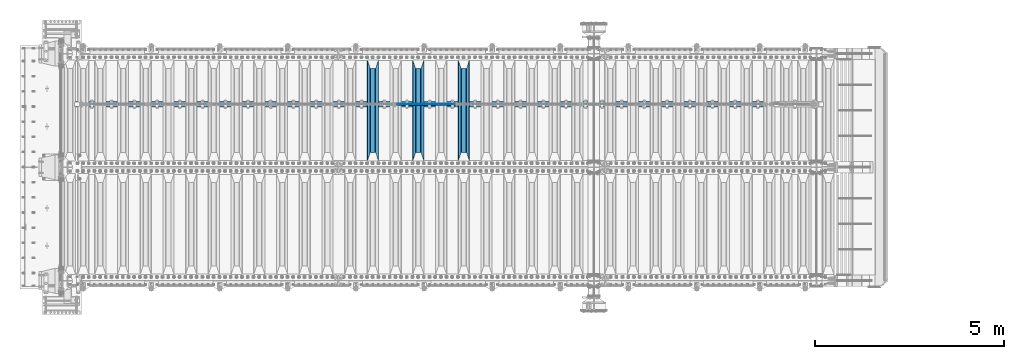
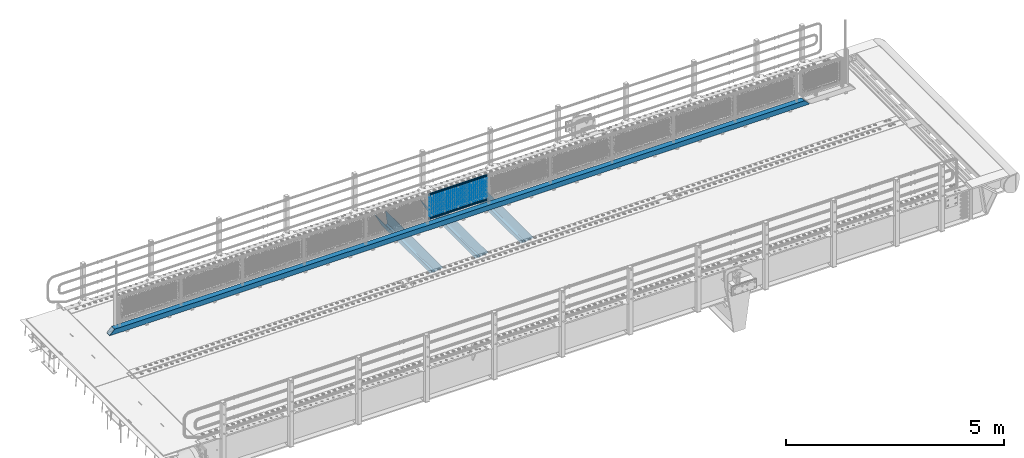
# One storey, part 123 of 242: 23 beams.
"""IFC2X3 building model written with IfcOpenShell, lengths in millimetres."""

import ifcopenshell
import ifcopenshell.guid

model = None  # the IFC model being written
_history = None  # IfcOwnerHistory: only IFC2X3 demands one
_inside = {}  # id of a spatial element -> (the spatial element, [elements in it])
_under = {}  # id of a project, library or spatial element -> (it, [spatial elements below it])
_declared = {}  # id of a project -> (the project, [libraries it declares])
_typed = {}  # id of a type object -> (the type object, [elements of that type])
_made_of = {}  # id of a material, layer set ... -> (it, [elements and type objects made of it])


def new_model(schema):
    """Start an empty IFC model of exactly this schema.

    Asked for "IFC4X3", IfcOpenShell would pick the latest addendum, in which some entities
    have other attributes; the version numbers below select the first issue.
    IFC2X3 requires an IfcOwnerHistory on every rooted entity: one is made here for all.
    """
    global model, _history
    if schema == "IFC4X3":
        model = ifcopenshell.file(schema_version=(4, 3, 0, 0))
    else:
        model = ifcopenshell.file(schema=schema)
    _inside.clear()
    _under.clear()
    _declared.clear()
    _typed.clear()
    _made_of.clear()
    _history = None
    if model.schema == "IFC2X3":
        org = make("IfcOrganization", Name="unknown")
        user = make(
            "IfcPersonAndOrganization",
            ThePerson=make("IfcPerson", FamilyName="unknown"),
            TheOrganization=org,
        )
        app = make(
            "IfcApplication",
            ApplicationDeveloper=org,
            Version="unknown",
            ApplicationFullName="unknown",
            ApplicationIdentifier="unknown",
        )
        _history = make(
            "IfcOwnerHistory",
            OwningUser=user,
            OwningApplication=app,
            ChangeAction="ADDED",
            CreationDate=0,
        )
    return model


def make(cls, **values):
    """One entity of the class cls with the attributes given. An attribute that is None is left unset."""
    return model.create_entity(
        cls, **{name: value for name, value in values.items() if value is not None}
    )


def rooted(cls, **values):
    """An entity with a GlobalId (a new one), such as an element, a storey or a relation."""
    return make(cls, GlobalId=ifcopenshell.guid.new(), OwnerHistory=_history, **values)


def si_unit(unit_type, name, prefix=None):
    """IfcSIUnit, for example si_unit("LENGTHUNIT", "METRE", prefix="MILLI")."""
    return make("IfcSIUnit", UnitType=unit_type, Prefix=prefix, Name=name)


def assignment(units):
    """IfcUnitAssignment: the units of a project."""
    return None if units is None else make("IfcUnitAssignment", Units=units)


def point(xyz):
    """IfcCartesianPoint."""
    return None if xyz is None else make("IfcCartesianPoint", Coordinates=xyz)


def direction(xyz):
    """IfcDirection."""
    return None if xyz is None else make("IfcDirection", DirectionRatios=xyz)


def frame(location, z_axis=None, x_axis=None):
    """IfcAxis2Placement3D, a coordinate frame: its origin and axes. An axis left out is left unset."""
    return make(
        "IfcAxis2Placement3D",
        Location=point(location),
        Axis=direction(z_axis),
        RefDirection=direction(x_axis),
    )


def origin_with_axes():
    """The frame at (0, 0, 0) with the z axis (0, 0, 1) and the x axis (1, 0, 0) written out."""
    return frame((0.0, 0.0, 0.0), z_axis=(0.0, 0.0, 1.0), x_axis=(1.0, 0.0, 0.0))


def place(relative_to, where):
    """IfcLocalPlacement: puts the frame where relative to a parent placement (None: the world)."""
    return make(
        "IfcLocalPlacement", PlacementRelTo=relative_to, RelativePlacement=where
    )


def context(
    kind, dimensions, precision=None, world=None, true_north=None, identifier=None
):
    """IfcGeometricRepresentationContext, for example the 3D "Model" context."""
    return make(
        "IfcGeometricRepresentationContext",
        ContextIdentifier=identifier,
        ContextType=kind,
        CoordinateSpaceDimension=dimensions,
        Precision=precision,
        WorldCoordinateSystem=world,
        TrueNorth=true_north,
    )


def subcontext(parent, identifier, kind, view, scale=None):
    """IfcGeometricRepresentationSubContext, for example "Body" below "Model"."""
    return make(
        "IfcGeometricRepresentationSubContext",
        ContextIdentifier=identifier,
        ContextType=kind,
        ParentContext=parent,
        TargetScale=scale,
        TargetView=view,
    )


def project(units=None, contexts=None):
    """IfcProject with its units and contexts."""
    return rooted(
        "IfcProject",
        Name="project",
        RepresentationContexts=contexts,
        UnitsInContext=assignment(units),
    )


def spatial(cls, under=None, at=None, **own):
    """A site, building, storey or space (cls), placed at a placement, below another one or the project."""
    s = rooted(cls, ObjectPlacement=at, **own)
    if under is not None:
        _under.setdefault(under.id(), (under, []))[1].append(s)
    return s


def faces_of(points, faces, orient=None, outer=None):
    """IfcFace entities. A face is a list of loops; a loop is a list of indices into points, from 0.

    orient and outer hold one flag for each loop. By default every Orientation is true, the
    first loop of a face is its IfcFaceOuterBound and the others are IfcFaceBound.
    """
    made = []
    for i, loops in enumerate(faces):
        bounds = []
        for j, loop in enumerate(loops):
            is_outer = j == 0 if outer is None else outer[i][j]
            bounds.append(
                make(
                    "IfcFaceOuterBound" if is_outer else "IfcFaceBound",
                    Bound=make("IfcPolyLoop", Polygon=[points[k] for k in loop]),
                    Orientation=True if orient is None else orient[i][j],
                )
            )
        made.append(make("IfcFace", Bounds=bounds))
    return made


def faceted_brep(points, faces, orient=None, outer=None, voids=None):
    """IfcFacetedBrep: a solid bounded by flat faces; with voids (closed shells), ...WithVoids."""
    shared = [point(p) for p in points]
    hull = make("IfcClosedShell", CfsFaces=faces_of(shared, faces, orient, outer))
    if voids is None:
        return make("IfcFacetedBrep", Outer=hull)
    return make(
        "IfcFacetedBrepWithVoids",
        Outer=hull,
        Voids=[
            make(cls, CfsFaces=faces_of(shared, fs, o, b)) for cls, fs, o, b in voids
        ],
    )


def shape(context_of_items, identifier, shape_type, items):
    """IfcShapeRepresentation: the items that make up one representation, for example the "Body"."""
    return make(
        "IfcShapeRepresentation",
        ContextOfItems=context_of_items,
        RepresentationIdentifier=identifier,
        RepresentationType=shape_type,
        Items=items,
    )


def material(Name=None, Category=None):
    """IfcMaterial."""
    return make("IfcMaterial", Name=Name, Category=Category)


def made_of(thing, what):
    """Note that an element or type object is made of a material, layer set ...; save() writes the relation."""
    if what is not None:
        _made_of.setdefault(what.id(), (what, []))[1].append(thing)
    return thing


def type_object(cls, material=None, **own):
    """A type object (cls), such as IfcWallType, which elements share."""
    return made_of(rooted(cls, **own), material)


def element(
    cls,
    number,
    at=None,
    inside=None,
    cuts=None,
    type_object=None,
    material=None,
    context=None,
    identifier="Body",
    shape_type=None,
    held_by="IfcProductDefinitionShape",
    body=None,
    shapes=None,
    **own,
):
    """One element of the class cls, such as IfcWall. Its Tag is "e" and its number.

    at: its placement. inside: the storey or other place that contains it. cuts: it is an
    opening in that element (IfcRelVoidsElement). A single representation is given by context,
    identifier, shape_type and body (its items); several are given by shapes. held_by: the class
    of the entity that holds the representations. save() writes the other relations.
    """
    e = rooted(cls, Tag="e%d" % number, ObjectPlacement=at, **own)
    if body is not None:
        shapes = [shape(context, identifier, shape_type, body)]
    if shapes is not None:
        e.Representation = make(held_by, Representations=shapes)
    if inside is not None:
        _inside.setdefault(inside.id(), (inside, []))[1].append(e)
    if cuts is not None:
        rooted(
            "IfcRelVoidsElement", RelatingBuildingElement=cuts, RelatedOpeningElement=e
        )
    if type_object is not None:
        _typed.setdefault(type_object.id(), (type_object, []))[1].append(e)
    return made_of(e, material)


def aggregate(whole, parts):
    """IfcRelAggregates: a whole, such as a stair, and the parts it consists of."""
    return rooted("IfcRelAggregates", RelatingObject=whole, RelatedObjects=parts)


def save(model, path):
    """Write the relations noted so far, then the file.

    IfcRelAggregates (storeys below a building ...), IfcRelContainedInSpatialStructure (elements
    in a storey), IfcRelDefinesByType, IfcRelAssociatesMaterial and IfcRelDeclares: one each for
    every whole, place, type object, material and project.
    """
    for whole, parts in _under.values():
        aggregate(whole, parts)
    for where, things in _inside.values():
        rooted(
            "IfcRelContainedInSpatialStructure",
            RelatedElements=things,
            RelatingStructure=where,
        )
    for kind, things in _typed.values():
        rooted("IfcRelDefinesByType", RelatedObjects=things, RelatingType=kind)
    for what, things in _made_of.values():
        rooted("IfcRelAssociatesMaterial", RelatedObjects=things, RelatingMaterial=what)
    for by, libraries in _declared.values():
        rooted("IfcRelDeclares", RelatingContext=by, RelatedDefinitions=libraries)
    model.write(path)


model = new_model("IFC2X3")

# Units and contexts
model_context = context("Model", 3, precision=1e-05, world=origin_with_axes())
body_context = subcontext(model_context, "Body", "Model", "MODEL_VIEW")
ifc_project = project(units=[si_unit("LENGTHUNIT", "METRE", prefix="MILLI"), si_unit("AREAUNIT", "SQUARE_METRE"), si_unit("VOLUMEUNIT", "CUBIC_METRE"), si_unit("MASSUNIT", "GRAM", prefix="KILO"), si_unit("TIMEUNIT", "SECOND"), si_unit("PLANEANGLEUNIT", "RADIAN"), si_unit("SOLIDANGLEUNIT", "STERADIAN"), si_unit("THERMODYNAMICTEMPERATUREUNIT", "DEGREE_CELSIUS"), si_unit("LUMINOUSINTENSITYUNIT", "LUMEN")], contexts=[model_context])

# Site, building, storey
site_placement = place(None, origin_with_axes())
site = spatial("IfcSite", under=ifc_project, at=site_placement, CompositionType="ELEMENT")
building_placement = place(site_placement, origin_with_axes())
building = spatial("IfcBuilding", under=site, at=building_placement, Name="Standard", CompositionType="ELEMENT")
storey_placement = place(building_placement, origin_with_axes())
storey = spatial("IfcBuildingStorey", under=building, at=storey_placement, Name="Undefined", CompositionType="ELEMENT", Elevation=0.0)

# Beams
ifc_material_1 = material(Name="Misc_Undefined")
beam_type_1 = type_object("IfcBeamType", Name="D3", PredefinedType="NOTDEFINED")
for number, where, z_axis, x_axis in (
    (1, (-33609.0, -19329.5, 851.596999999999), (0.0, 0.0, 1.0), (1.0, 0.0, 0.0)),
    (2, (-33609.0, -19329.5, 669.452), (0.0, 0.0, 1.0), (1.0, 0.0, 0.0)),
    (3, (-33609.0, -19329.5, 523.736), (0.0, 0.0, 1.0), (1.0, 0.0, 0.0)),
    (4, (-33609.0, -19329.5, 487.307), (0.0, 0.0, 1.0), (1.0, 0.0, 0.0)),
    (5, (-33609.0, -19329.5, 705.881), (0.0, 0.0, 1.0), (1.0, 0.0, 0.0)),
    (6, (-33609.0, -19329.5, 596.594), (0.0, 0.0, 1.0), (1.0, 0.0, 0.0)),
    (7, (-33609.0, -19329.5, 450.878), (0.0, 0.0, 1.0), (1.0, 0.0, 0.0)),
    (8, (-33609.0, -19329.5, 815.167999999999), (0.0, 0.0, 1.0), (1.0, 0.0, 0.0)),
    (9, (-33609.0, -19329.5, 888.025999999999), (0.0, 0.0, 1.0), (1.0, 0.0, 0.0)),
    (10, (-33609.0, -19329.5, 778.738999999999), (0.0, 0.0, 1.0), (1.0, 0.0, 0.0)),
    (11, (-33609.0, -19329.5, 742.309999999999), (0.0, 0.0, 1.0), (1.0, 0.0, 0.0)),
    (12, (-33609.0, -19329.5, 633.023), (0.0, 0.0, 1.0), (1.0, 0.0, 0.0)),
    (13, (-33609.0, -19329.5, 560.165), (0.0, 0.0, 1.0), (1.0, 0.0, 0.0)),
    (14, (-33609.0, -19329.5, 414.449), (0.0, 0.0, 1.0), (1.0, 0.0, 0.0)),
):
    element("IfcBeam", number, at=place(storey_placement, frame(where, z_axis=z_axis, x_axis=x_axis)), inside=storey, type_object=beam_type_1, material=ifc_material_1, ObjectType="D3", context=body_context, shape_type="Brep", body=[
        faceted_brep([(0.0, -1.50000000000364, 0.0), (-3.63797880709171e-12, -0.750000000003638, -1.29903810567669), (1523.0, -0.75, -1.29903810567669), (1523.0, -1.5, 0.0), (0.0, 0.749999999996362, -1.29903810567669), (1523.0, 0.75, -1.29903810567669), (-3.63797880709171e-12, 1.49999999999636, 0.0), (1523.0, 1.5, 0.0), (0.0, 0.749999999996362, 1.29903810567669), (1523.0, 0.75, 1.29903810567669), (-3.63797880709171e-12, -0.750000000003638, 1.29903810567669), (1523.0, -0.75, 1.29903810567669)], [[[0, 1, 2, 3]], [[1, 4, 5, 2]], [[4, 6, 7, 5]], [[6, 8, 9, 7]], [[8, 10, 11, 9]], [[10, 0, 3, 11]], [[5, 7, 9, 11, 3, 2]], [[10, 8, 6, 4, 1, 0]]]),
    ])
beam_1_placement = place(storey_placement, frame((-33584.0, -19329.5, 353.02), z_axis=(0.0, 0.0, 1.0), x_axis=(1.0, 0.0, 0.0)))
element("IfcBeam", 15, at=beam_1_placement, inside=storey, type_object=beam_type_1, material=ifc_material_1, ObjectType="D3", context=body_context, shape_type="Brep", body=[
    faceted_brep([(0.0, -1.50000000000364, 0.0), (-3.63797880709171e-12, -0.750000000003638, -1.29903810567669), (1473.0, -0.75, -1.29903810567669), (1473.0, -1.5, 0.0), (0.0, 0.749999999996362, -1.29903810567669), (1473.0, 0.75, -1.29903810567663), (-3.63797880709171e-12, 1.49999999999636, 0.0), (1473.0, 1.5, 0.0), (0.0, 0.749999999996362, 1.29903810567669), (1473.0, 0.75, 1.29903810567669), (-3.63797880709171e-12, -0.750000000003638, 1.29903810567669), (1473.0, -0.75, 1.29903810567669)], [[[0, 1, 2, 3]], [[1, 4, 5, 2]], [[4, 6, 7, 5]], [[6, 8, 9, 7]], [[8, 10, 11, 9]], [[10, 0, 3, 11]], [[5, 7, 9, 11, 3, 2]], [[10, 8, 6, 4, 1, 0]]]),
])
beam_2_placement = place(storey_placement, frame((-33609.0, -19329.5, 378.02), z_axis=(0.0, 0.0, 1.0), x_axis=(1.0, 0.0, 0.0)))
element("IfcBeam", 16, at=beam_2_placement, inside=storey, type_object=beam_type_1, material=ifc_material_1, ObjectType="D3", context=body_context, shape_type="Brep", body=[
    faceted_brep([(0.0, -1.50000000000364, 0.0), (-3.63797880709171e-12, -0.750000000003638, -1.29903810567669), (1523.0, -0.75, -1.29903810567669), (1523.0, -1.5, 0.0), (0.0, 0.749999999996362, -1.29903810567669), (1523.0, 0.75, -1.29903810567669), (-3.63797880709171e-12, 1.49999999999636, 0.0), (1523.0, 1.5, 0.0), (0.0, 0.749999999996362, 1.29903810567669), (1523.0, 0.75, 1.29903810567669), (-3.63797880709171e-12, -0.750000000003638, 1.29903810567669), (1523.0, -0.75, 1.29903810567669)], [[[0, 1, 2, 3]], [[1, 4, 5, 2]], [[4, 6, 7, 5]], [[6, 8, 9, 7]], [[8, 10, 11, 9]], [[10, 0, 3, 11]], [[5, 7, 9, 11, 3, 2]], [[10, 8, 6, 4, 1, 0]]]),
])
beam_3_placement = place(storey_placement, frame((-33584.0, -19329.5, 913.02), z_axis=(0.0, 0.0, 1.0), x_axis=(1.0, 0.0, 0.0)))
element("IfcBeam", 17, at=beam_3_placement, inside=storey, type_object=beam_type_1, material=ifc_material_1, ObjectType="D3", context=body_context, shape_type="Brep", body=[
    faceted_brep([(0.0, -1.50000000000364, 0.0), (-3.63797880709171e-12, -0.750000000003638, -1.29903810567669), (1473.0, -0.75, -1.29903810567669), (1473.0, -1.5, 0.0), (0.0, 0.749999999996362, -1.29903810567669), (1473.0, 0.75, -1.29903810567663), (-3.63797880709171e-12, 1.49999999999636, 0.0), (1473.0, 1.5, 0.0), (0.0, 0.749999999996362, 1.29903810567669), (1473.0, 0.75, 1.29903810567669), (-3.63797880709171e-12, -0.750000000003638, 1.29903810567669), (1473.0, -0.75, 1.29903810567669)], [[[0, 1, 2, 3]], [[1, 4, 5, 2]], [[4, 6, 7, 5]], [[6, 8, 9, 7]], [[8, 10, 11, 9]], [[10, 0, 3, 11]], [[5, 7, 9, 11, 3, 2]], [[10, 8, 6, 4, 1, 0]]]),
])
ifc_material_2 = material()
beam_type_2 = type_object("IfcBeamType", PredefinedType="NOTDEFINED")
beam_4_placement = place(storey_placement, frame((-33629.15, -19335.5, 969.849999999999), z_axis=(0.0, 0.0, 1.0), x_axis=(1.0, 0.0, 0.0)))
element("IfcBeam", 18, at=beam_4_placement, inside=storey, type_object=beam_type_2, material=ifc_material_2, context=body_context, shape_type="Brep", body=[
    faceted_brep([(0.0, -25.3499999999985, 0.0), (0.0, -23.4203461491597, 9.70102501045403), (1563.0, -23.4203461491597, 9.70102501045506), (1563.0, -25.3499999999985, 0.0), (0.0, -17.9251569030785, 17.9251569030785), (1563.0, -17.9251569030785, 17.925156903079), (0.0, -9.70102501045403, 23.4203461491597), (1563.0, -9.70102501045403, 23.4203461491611), (0.0, 0.0, 25.3499999999985), (1563.0, 0.0, 25.35), (0.0, 9.70102501045403, 23.4203461491597), (1563.0, 9.70102501045403, 23.4203461491611), (0.0, 17.9251569030785, 17.9251569030785), (1563.0, 17.9251569030785, 17.925156903079), (0.0, 23.4203461491597, 9.70102501045403), (1563.0, 23.4203461491597, 9.70102501045506), (0.0, 25.3499999999985, 0.0), (1563.0, 25.3499999999985, 0.0), (0.0, 23.4203461491597, -9.70102501045403), (1563.0, 23.4203461491597, -9.70102501045506), (0.0, 17.9251569030785, -17.9251569030785), (1563.0, 17.9251569030785, -17.925156903079), (0.0, 9.70102501045403, -23.4203461491597), (1563.0, 9.70102501045403, -23.4203461491611), (0.0, 0.0, -25.3499999999985), (1563.0, 0.0, -25.35), (0.0, -9.70102501045403, -23.4203461491597), (1563.0, -9.70102501045403, -23.4203461491611), (0.0, -17.9251569030785, -17.9251569030785), (1563.0, -17.9251569030785, -17.925156903079), (0.0, -23.4203461491597, -9.70102501045403), (1563.0, -23.4203461491597, -9.70102501045506), (0.0, -30.1500000000015, 0.0), (0.0, -27.8549679052157, -11.5379054858058), (1563.0, -27.8549679052157, -11.5379054858075), (1563.0, -30.1500000000015, 0.0), (0.0, -21.3192694527752, -21.3192694527752), (1563.0, -21.3192694527752, -21.3192694527744), (0.0, -11.5379054858058, -27.8549679052157), (1563.0, -11.5379054858058, -27.8549679052153), (0.0, 0.0, -30.1500000000015), (1563.0, 0.0, -30.15), (0.0, 11.5379054858058, -27.8549679052157), (1563.0, 11.5379054858058, -27.8549679052153), (0.0, 21.3192694527752, -21.3192694527752), (1563.0, 21.3192694527752, -21.3192694527744), (0.0, 27.8549679052157, -11.5379054858058), (1563.0, 27.8549679052157, -11.5379054858074), (0.0, 30.1500000000015, 0.0), (1563.0, 30.1500000000015, 0.0), (0.0, 27.8549679052157, 11.5379054858058), (1563.0, 27.8549679052157, 11.5379054858074), (0.0, 21.3192694527752, 21.3192694527752), (1563.0, 21.3192694527752, 21.3192694527744), (0.0, 11.5379054858058, 27.8549679052157), (1563.0, 11.5379054858058, 27.8549679052153), (0.0, 0.0, 30.1500000000015), (1563.0, 0.0, 30.15), (0.0, -11.5379054858058, 27.8549679052157), (1563.0, -11.5379054858058, 27.8549679052153), (0.0, -21.3192694527752, 21.3192694527752), (1563.0, -21.3192694527752, 21.3192694527744), (0.0, -27.8549679052157, 11.5379054858058), (1563.0, -27.8549679052157, 11.5379054858074)], [[[0, 1, 2, 3]], [[1, 4, 5, 2]], [[4, 6, 7, 5]], [[6, 8, 9, 7]], [[8, 10, 11, 9]], [[10, 12, 13, 11]], [[12, 14, 15, 13]], [[14, 16, 17, 15]], [[16, 18, 19, 17]], [[18, 20, 21, 19]], [[20, 22, 23, 21]], [[22, 24, 25, 23]], [[24, 26, 27, 25]], [[26, 28, 29, 27]], [[28, 30, 31, 29]], [[30, 0, 3, 31]], [[32, 33, 34, 35]], [[33, 36, 37, 34]], [[36, 38, 39, 37]], [[38, 40, 41, 39]], [[40, 42, 43, 41]], [[42, 44, 45, 43]], [[44, 46, 47, 45]], [[46, 48, 49, 47]], [[48, 50, 51, 49]], [[50, 52, 53, 51]], [[52, 54, 55, 53]], [[54, 56, 57, 55]], [[56, 58, 59, 57]], [[58, 60, 61, 59]], [[60, 62, 63, 61]], [[62, 32, 35, 63]], [[37, 39, 41, 43, 45, 47, 49, 51, 53, 55, 57, 59, 61, 63, 35, 34], [5, 7, 9, 11, 13, 15, 17, 19, 21, 23, 25, 27, 29, 31, 3, 2]], [[62, 60, 58, 56, 54, 52, 50, 48, 46, 44, 42, 40, 38, 36, 33, 32], [30, 28, 26, 24, 22, 20, 18, 16, 14, 12, 10, 8, 6, 4, 1, 0]]]),
])
beam_5_placement = place(storey_placement, frame((-33629.15, -19335.5, 298.170000000001), z_axis=(0.0, 0.0, 1.0), x_axis=(1.0, 0.0, 0.0)))
element("IfcBeam", 19, at=beam_5_placement, inside=storey, type_object=beam_type_2, material=ifc_material_2, context=body_context, shape_type="Brep", body=[
    faceted_brep([(0.0, -25.3499999999985, 0.0), (0.0, -23.4203461491597, 9.70102501045403), (1563.0, -23.4203461491597, 9.70102501045506), (1563.0, -25.3499999999985, 0.0), (0.0, -17.9251569030785, 17.9251569030785), (1563.0, -17.9251569030785, 17.925156903079), (0.0, -9.70102501045403, 23.4203461491597), (1563.0, -9.70102501045403, 23.4203461491611), (0.0, 0.0, 25.3499999999985), (1563.0, 0.0, 25.35), (0.0, 9.70102501045403, 23.4203461491597), (1563.0, 9.70102501045403, 23.4203461491611), (0.0, 17.9251569030785, 17.9251569030785), (1563.0, 17.9251569030785, 17.925156903079), (0.0, 23.4203461491597, 9.70102501045403), (1563.0, 23.4203461491597, 9.70102501045506), (0.0, 25.3499999999985, 0.0), (1563.0, 25.3499999999985, 0.0), (0.0, 23.4203461491597, -9.70102501045403), (1563.0, 23.4203461491597, -9.70102501045506), (0.0, 17.9251569030785, -17.9251569030785), (1563.0, 17.9251569030785, -17.925156903079), (0.0, 9.70102501045403, -23.4203461491597), (1563.0, 9.70102501045403, -23.4203461491611), (0.0, 0.0, -25.3499999999985), (1563.0, 0.0, -25.35), (0.0, -9.70102501045403, -23.4203461491597), (1563.0, -9.70102501045403, -23.4203461491611), (0.0, -17.9251569030785, -17.9251569030785), (1563.0, -17.9251569030785, -17.925156903079), (0.0, -23.4203461491597, -9.70102501045403), (1563.0, -23.4203461491597, -9.70102501045506), (0.0, -30.1500000000015, 0.0), (0.0, -27.8549679052157, -11.5379054858058), (1563.0, -27.8549679052157, -11.5379054858075), (1563.0, -30.1500000000015, 0.0), (0.0, -21.3192694527752, -21.3192694527752), (1563.0, -21.3192694527752, -21.3192694527744), (0.0, -11.5379054858058, -27.8549679052157), (1563.0, -11.5379054858058, -27.8549679052153), (0.0, 0.0, -30.1500000000015), (1563.0, 0.0, -30.15), (0.0, 11.5379054858058, -27.8549679052157), (1563.0, 11.5379054858058, -27.8549679052153), (0.0, 21.3192694527752, -21.3192694527752), (1563.0, 21.3192694527752, -21.3192694527744), (0.0, 27.8549679052157, -11.5379054858058), (1563.0, 27.8549679052157, -11.5379054858074), (0.0, 30.1500000000015, 0.0), (1563.0, 30.1500000000015, 0.0), (0.0, 27.8549679052157, 11.5379054858058), (1563.0, 27.8549679052157, 11.5379054858074), (0.0, 21.3192694527752, 21.3192694527752), (1563.0, 21.3192694527752, 21.3192694527744), (0.0, 11.5379054858058, 27.8549679052157), (1563.0, 11.5379054858058, 27.8549679052153), (0.0, 0.0, 30.1500000000015), (1563.0, 0.0, 30.15), (0.0, -11.5379054858058, 27.8549679052157), (1563.0, -11.5379054858058, 27.8549679052153), (0.0, -21.3192694527752, 21.3192694527752), (1563.0, -21.3192694527752, 21.3192694527744), (0.0, -27.8549679052157, 11.5379054858058), (1563.0, -27.8549679052157, 11.5379054858074)], [[[0, 1, 2, 3]], [[1, 4, 5, 2]], [[4, 6, 7, 5]], [[6, 8, 9, 7]], [[8, 10, 11, 9]], [[10, 12, 13, 11]], [[12, 14, 15, 13]], [[14, 16, 17, 15]], [[16, 18, 19, 17]], [[18, 20, 21, 19]], [[20, 22, 23, 21]], [[22, 24, 25, 23]], [[24, 26, 27, 25]], [[26, 28, 29, 27]], [[28, 30, 31, 29]], [[30, 0, 3, 31]], [[32, 33, 34, 35]], [[33, 36, 37, 34]], [[36, 38, 39, 37]], [[38, 40, 41, 39]], [[40, 42, 43, 41]], [[42, 44, 45, 43]], [[44, 46, 47, 45]], [[46, 48, 49, 47]], [[48, 50, 51, 49]], [[50, 52, 53, 51]], [[52, 54, 55, 53]], [[54, 56, 57, 55]], [[56, 58, 59, 57]], [[58, 60, 61, 59]], [[60, 62, 63, 61]], [[62, 32, 35, 63]], [[37, 39, 41, 43, 45, 47, 49, 51, 53, 55, 57, 59, 61, 63, 35, 34], [5, 7, 9, 11, 13, 15, 17, 19, 21, 23, 25, 27, 29, 31, 3, 2]], [[62, 60, 58, 56, 54, 52, 50, 48, 46, 44, 42, 40, 38, 36, 33, 32], [30, 28, 26, 24, 22, 20, 18, 16, 14, 12, 10, 8, 6, 4, 1, 0]]]),
])
beam_type_3 = type_object("IfcBeamType", PredefinedType="NOTDEFINED")
beam_6_placement = place(storey_placement, frame((-42125.0, -19335.5, 98.0199999999977), z_axis=(0.0, 0.0, 1.0), x_axis=(1.0, 0.0, 0.0)))
element("IfcBeam", 20, at=beam_6_placement, inside=storey, type_object=beam_type_3, material=ifc_material_2, context=body_context, shape_type="Brep", body=[
    faceted_brep([(0.0, -70.0, -70.0), (0.0, 70.0, -70.0), (18565.0, 70.0, -70.0), (18565.0, -70.0, -70.0), (18434.8884698478, -70.0, 70.0), (18434.8884698478, 70.0, 70.0), (130.111530936148, 70.0, 70.0), (130.111528976151, -70.0, 70.0), (18565.0, -70.0, -60.0079600980746), (0.0, -70.0, -60.0079591069155), (18444.8964362873, -60.0, 60.0), (18565.0, -60.0, -60.0), (0.0, -60.0, -60.0), (120.103562690863, -60.0, 60.0), (18444.8964362873, 60.0, 60.0), (120.10356437086, 60.0, 60.0), (18565.0, 60.0, -60.0), (0.0, 60.0, -60.0), (18565.0, 70.0, -60.0079600980746), (0.0, 70.0, -60.0079610653521)], [[[0, 1, 2, 3]], [[4, 5, 6, 7]], [[0, 3, 8, 4, 7, 9]], [[10, 11, 12, 13]], [[14, 10, 13, 15]], [[16, 14, 15, 17]], [[4, 8, 11, 10, 14, 16, 18, 5]], [[11, 8, 3, 2, 18, 16]], [[17, 12, 11, 16]], [[1, 0, 9, 12, 17, 19]], [[5, 18, 2, 1, 19, 6]], [[17, 15, 13, 12, 9, 7, 6, 19]]]),
])
ifc_material_3 = material(Name="STEEL/S355N")
beam_type_4 = type_object("IfcBeamType", PredefinedType="NOTDEFINED")
beam_7_placement = place(storey_placement, frame((-31850.0, -20825.0, -115.0), z_axis=(0.0, 0.0, 1.0), x_axis=(0.0, 1.0, 0.0)))
element("IfcBeam", 21, at=beam_7_placement, inside=storey, type_object=beam_type_4, material=ifc_material_3, context=body_context, shape_type="Brep", body=[
    faceted_brep([(0.0, 150.0, 115.0), (0.0, 143.689999999999, 115.0), (2650.00000000297, 143.689999999999, 115.0), (2650.00000000297, 150.0, 115.0), (2650.00000000297, 142.059565218402, 110.000000003099), (2650.00000000297, 148.369565218403, 110.000000003099), (2441.90079219209, -80.1103600731112, -98.0992078077845), (2437.7588105432, -77.5672621345584, -102.241189456673), (2434.06523489747, -74.4080125315522, -105.934765102404), (2430.91086095089, -70.710272125576, -109.089139048974), (2428.37322971128, -66.5649389910068, -111.626770288588), (2426.51472138055, -62.0739139532889, -113.485278619323), (2425.38102192092, -57.3475956567672, -114.618978078955), (2424.99999999987, -52.5021667386536, -115.0), (2424.99999999987, 52.5021667386536, -115.0), (2425.38102192092, 57.3475956567672, -114.618978078955), (2426.51472138055, 62.0739139532889, -113.485278619323), (2428.37322971128, 66.5649389910068, -111.626770288588), (2430.91086095089, 70.710272125576, -109.089139048974), (2434.06523489747, 74.4080125315522, -105.934765102404), (2437.7588105432, 77.5672621345584, -102.241189456673), (2441.90079219209, 80.1103600731112, -98.0992078077846), (2446.38936140511, 81.9747917625791, -93.6106385947584), (2448.2494850041, 76.2713538057251, -91.7505149957729), (2444.62967112262, 74.76777986261, -95.3703288772456), (2441.28936334126, 72.7168944282894, -98.710636658607), (2438.31067330438, 70.1691124903846, -101.689326695487), (2435.76682334747, 67.1870637758839, -104.233176652398), (2433.72034654133, 63.8440531834895, -106.279653458539), (2432.22154950042, 60.222258798236, -107.778450499454), (2431.30727574265, 56.4107117849089, -108.692724257221), (2430.99999999987, 52.5031078186876, -109.0), (2430.99999999987, -52.5031078186876, -109.0), (2431.30727574265, -56.4107117849089, -108.692724257221), (2432.22154950042, -60.222258798236, -107.778450499454), (2433.72034654133, -63.8440531834895, -106.279653458539), (2435.76682334747, -67.1870637758839, -104.233176652398), (2438.31067330438, -70.1691124903846, -101.689326695487), (2441.28936334126, -72.7168944282894, -98.7106366586071), (2444.62967112262, -74.76777986261, -95.3703288772457), (2448.2494850041, -76.2713538057251, -91.7505149957729), (2650.00000000297, -142.059565218402, 110.000000003099), (2650.00000000297, -148.369565218403, 110.000000003099), (2446.38936140511, -81.9747917625791, -93.6106385947584), (2650.00000000297, -143.689999999999, 115.0), (2650.00000000297, -150.0, 115.0), (0.0, -143.689999999999, 115.0), (0.0, -150.0, 115.0), (0.0, -148.369565218261, 110.000000002669), (203.610638597427, -81.9747917625791, -93.6106385947584), (208.099207810454, -80.1103600731112, -98.0992078077845), (212.241189459342, -77.5672621345584, -102.241189456673), (215.934765105074, -74.4080125315522, -105.934765102404), (219.089139051644, -70.710272125576, -109.089139048974), (221.626770291256, -66.5649389910068, -111.626770288588), (223.485278621993, -62.0739139532889, -113.485278619323), (224.618978081624, -57.3475956567672, -114.618978078955), (225.00000000267, -52.5021667386536, -115.0), (225.00000000267, 52.5021667386536, -115.0), (224.618978081624, 57.3475956567672, -114.618978078955), (223.485278621993, 62.0739139532889, -113.485278619323), (221.626770291256, 66.5649389910068, -111.626770288588), (219.089139051644, 70.710272125576, -109.089139048974), (215.934765105074, 74.4080125315522, -105.934765102404), (212.241189459342, 77.5672621345584, -102.241189456673), (208.099207810454, 80.1103600731112, -98.0992078077846), (203.610638597427, 81.9747917625791, -93.6106385947584), (0.0, 148.369565218261, 110.000000002669), (0.0, 142.05956521826, 110.000000002669), (201.750514998443, 76.2713538057251, -91.7505149957729), (205.370328879915, 74.76777986261, -95.3703288772456), (208.710636661275, 72.7168944282894, -98.710636658607), (211.689326698157, 70.1691124903846, -101.689326695487), (214.233176655067, 67.1870637758839, -104.233176652398), (216.279653461206, 63.8440531834895, -106.279653458539), (217.778450502123, 60.222258798236, -107.778450499454), (218.69272425989, 56.4107117849089, -108.692724257221), (219.00000000267, 52.5031078186876, -109.0), (219.00000000267, -52.5031078186876, -109.0), (218.69272425989, -56.4107117849089, -108.692724257221), (217.778450502123, -60.222258798236, -107.778450499454), (216.279653461206, -63.8440531834895, -106.279653458539), (214.233176655067, -67.1870637758839, -104.233176652398), (211.689326698157, -70.1691124903846, -101.689326695487), (208.710636661275, -72.7168944282894, -98.7106366586071), (205.370328879915, -74.76777986261, -95.3703288772457), (201.750514998443, -76.2713538057251, -91.7505149957729), (0.0, -142.05956521826, 110.000000002669)], [[[0, 1, 2, 3]], [[3, 2, 4, 5]], [[6, 7, 8, 9, 10, 11, 12, 13, 14, 15, 16, 17, 18, 19, 20, 21, 22, 5, 4, 23, 24, 25, 26, 27, 28, 29, 30, 31, 32, 33, 34, 35, 36, 37, 38, 39, 40, 41, 42, 43]], [[44, 45, 42, 41]], [[46, 47, 45, 44]], [[43, 42, 45, 47, 48, 49]], [[6, 43, 49, 50]], [[7, 6, 50, 51]], [[8, 7, 51, 52]], [[9, 8, 52, 53]], [[10, 9, 53, 54]], [[11, 10, 54, 55]], [[12, 11, 55, 56]], [[13, 12, 56, 57]], [[14, 13, 57, 58]], [[15, 14, 58, 59]], [[16, 15, 59, 60]], [[17, 16, 60, 61]], [[18, 17, 61, 62]], [[19, 18, 62, 63]], [[20, 19, 63, 64]], [[21, 20, 64, 65]], [[22, 21, 65, 66]], [[0, 3, 5, 22, 66, 67]], [[1, 0, 67, 68]], [[23, 4, 2, 1, 68, 69]], [[24, 23, 69, 70]], [[25, 24, 70, 71]], [[26, 25, 71, 72]], [[27, 26, 72, 73]], [[28, 27, 73, 74]], [[29, 28, 74, 75]], [[30, 29, 75, 76]], [[31, 30, 76, 77]], [[32, 31, 77, 78]], [[33, 32, 78, 79]], [[34, 33, 79, 80]], [[35, 34, 80, 81]], [[36, 35, 81, 82]], [[37, 36, 82, 83]], [[38, 37, 83, 84]], [[39, 38, 84, 85]], [[40, 39, 85, 86]], [[46, 44, 41, 40, 86, 87]], [[47, 46, 87, 48]], [[86, 85, 84, 83, 82, 81, 80, 79, 78, 77, 76, 75, 74, 73, 72, 71, 70, 69, 68, 67, 66, 65, 64, 63, 62, 61, 60, 59, 58, 57, 56, 55, 54, 53, 52, 51, 50, 49, 48, 87]]]),
])
beam_8_placement = place(storey_placement, frame((-33050.0, -20825.0, -115.0), z_axis=(0.0, 0.0, 1.0), x_axis=(0.0, 1.0, 0.0)))
element("IfcBeam", 22, at=beam_8_placement, inside=storey, type_object=beam_type_4, material=ifc_material_3, context=body_context, shape_type="Brep", body=[
    faceted_brep([(0.0, 150.0, 115.0), (0.0, 143.689999999999, 115.0), (2650.00000000297, 143.689999999999, 115.0), (2650.00000000297, 150.0, 115.0), (2650.00000000297, 142.059565218402, 110.000000003099), (2650.00000000297, 148.369565218403, 110.000000003099), (2441.90079219209, -80.1103600731112, -98.0992078077845), (2437.7588105432, -77.5672621345584, -102.241189456673), (2434.06523489747, -74.4080125315522, -105.934765102404), (2430.91086095089, -70.710272125576, -109.089139048974), (2428.37322971128, -66.5649389910068, -111.626770288588), (2426.51472138055, -62.0739139532889, -113.485278619323), (2425.38102192092, -57.3475956567672, -114.618978078955), (2424.99999999987, -52.5021667386536, -115.0), (2424.99999999987, 52.5021667386536, -115.0), (2425.38102192092, 57.3475956567672, -114.618978078955), (2426.51472138055, 62.0739139532889, -113.485278619323), (2428.37322971128, 66.5649389910068, -111.626770288588), (2430.91086095089, 70.710272125576, -109.089139048974), (2434.06523489747, 74.4080125315522, -105.934765102404), (2437.7588105432, 77.5672621345584, -102.241189456673), (2441.90079219209, 80.1103600731112, -98.0992078077846), (2446.38936140511, 81.9747917625791, -93.6106385947584), (2448.2494850041, 76.2713538057251, -91.7505149957729), (2444.62967112262, 74.76777986261, -95.3703288772456), (2441.28936334126, 72.7168944282894, -98.710636658607), (2438.31067330438, 70.1691124903846, -101.689326695487), (2435.76682334747, 67.1870637758839, -104.233176652398), (2433.72034654133, 63.8440531834895, -106.279653458539), (2432.22154950042, 60.222258798236, -107.778450499454), (2431.30727574265, 56.4107117849089, -108.692724257221), (2430.99999999987, 52.5031078186876, -109.0), (2430.99999999987, -52.5031078186876, -109.0), (2431.30727574265, -56.4107117849089, -108.692724257221), (2432.22154950042, -60.222258798236, -107.778450499454), (2433.72034654133, -63.8440531834895, -106.279653458539), (2435.76682334747, -67.1870637758839, -104.233176652398), (2438.31067330438, -70.1691124903846, -101.689326695487), (2441.28936334126, -72.7168944282894, -98.7106366586071), (2444.62967112262, -74.76777986261, -95.3703288772457), (2448.2494850041, -76.2713538057251, -91.7505149957729), (2650.00000000297, -142.059565218402, 110.000000003099), (2650.00000000297, -148.369565218403, 110.000000003099), (2446.38936140511, -81.9747917625791, -93.6106385947584), (2650.00000000297, -143.689999999999, 115.0), (2650.00000000297, -150.0, 115.0), (0.0, -143.689999999999, 115.0), (0.0, -150.0, 115.0), (0.0, -148.369565218261, 110.000000002669), (203.610638597427, -81.9747917625791, -93.6106385947584), (208.099207810454, -80.1103600731112, -98.0992078077845), (212.241189459342, -77.5672621345584, -102.241189456673), (215.934765105074, -74.4080125315522, -105.934765102404), (219.089139051644, -70.710272125576, -109.089139048974), (221.626770291256, -66.5649389910068, -111.626770288588), (223.485278621993, -62.0739139532889, -113.485278619323), (224.618978081624, -57.3475956567672, -114.618978078955), (225.00000000267, -52.5021667386536, -115.0), (225.00000000267, 52.5021667386536, -115.0), (224.618978081624, 57.3475956567672, -114.618978078955), (223.485278621993, 62.0739139532889, -113.485278619323), (221.626770291256, 66.5649389910068, -111.626770288588), (219.089139051644, 70.710272125576, -109.089139048974), (215.934765105074, 74.4080125315522, -105.934765102404), (212.241189459342, 77.5672621345584, -102.241189456673), (208.099207810454, 80.1103600731112, -98.0992078077846), (203.610638597427, 81.9747917625791, -93.6106385947584), (0.0, 148.369565218261, 110.000000002669), (0.0, 142.05956521826, 110.000000002669), (201.750514998443, 76.2713538057251, -91.7505149957729), (205.370328879915, 74.76777986261, -95.3703288772456), (208.710636661275, 72.7168944282894, -98.710636658607), (211.689326698157, 70.1691124903846, -101.689326695487), (214.233176655067, 67.1870637758839, -104.233176652398), (216.279653461206, 63.8440531834895, -106.279653458539), (217.778450502123, 60.222258798236, -107.778450499454), (218.69272425989, 56.4107117849089, -108.692724257221), (219.00000000267, 52.5031078186876, -109.0), (219.00000000267, -52.5031078186876, -109.0), (218.69272425989, -56.4107117849089, -108.692724257221), (217.778450502123, -60.222258798236, -107.778450499454), (216.279653461206, -63.8440531834895, -106.279653458539), (214.233176655067, -67.1870637758839, -104.233176652398), (211.689326698157, -70.1691124903846, -101.689326695487), (208.710636661275, -72.7168944282894, -98.7106366586071), (205.370328879915, -74.76777986261, -95.3703288772457), (201.750514998443, -76.2713538057251, -91.7505149957729), (0.0, -142.05956521826, 110.000000002669)], [[[0, 1, 2, 3]], [[3, 2, 4, 5]], [[6, 7, 8, 9, 10, 11, 12, 13, 14, 15, 16, 17, 18, 19, 20, 21, 22, 5, 4, 23, 24, 25, 26, 27, 28, 29, 30, 31, 32, 33, 34, 35, 36, 37, 38, 39, 40, 41, 42, 43]], [[44, 45, 42, 41]], [[46, 47, 45, 44]], [[43, 42, 45, 47, 48, 49]], [[6, 43, 49, 50]], [[7, 6, 50, 51]], [[8, 7, 51, 52]], [[9, 8, 52, 53]], [[10, 9, 53, 54]], [[11, 10, 54, 55]], [[12, 11, 55, 56]], [[13, 12, 56, 57]], [[14, 13, 57, 58]], [[15, 14, 58, 59]], [[16, 15, 59, 60]], [[17, 16, 60, 61]], [[18, 17, 61, 62]], [[19, 18, 62, 63]], [[20, 19, 63, 64]], [[21, 20, 64, 65]], [[22, 21, 65, 66]], [[0, 3, 5, 22, 66, 67]], [[1, 0, 67, 68]], [[23, 4, 2, 1, 68, 69]], [[24, 23, 69, 70]], [[25, 24, 70, 71]], [[26, 25, 71, 72]], [[27, 26, 72, 73]], [[28, 27, 73, 74]], [[29, 28, 74, 75]], [[30, 29, 75, 76]], [[31, 30, 76, 77]], [[32, 31, 77, 78]], [[33, 32, 78, 79]], [[34, 33, 79, 80]], [[35, 34, 80, 81]], [[36, 35, 81, 82]], [[37, 36, 82, 83]], [[38, 37, 83, 84]], [[39, 38, 84, 85]], [[40, 39, 85, 86]], [[46, 44, 41, 40, 86, 87]], [[47, 46, 87, 48]], [[86, 85, 84, 83, 82, 81, 80, 79, 78, 77, 76, 75, 74, 73, 72, 71, 70, 69, 68, 67, 66, 65, 64, 63, 62, 61, 60, 59, 58, 57, 56, 55, 54, 53, 52, 51, 50, 49, 48, 87]]]),
])
beam_9_placement = place(storey_placement, frame((-34250.0, -20825.0, -115.0), z_axis=(0.0, 0.0, 1.0), x_axis=(0.0, 1.0, 0.0)))
element("IfcBeam", 23, at=beam_9_placement, inside=storey, type_object=beam_type_4, material=ifc_material_3, context=body_context, shape_type="Brep", body=[
    faceted_brep([(0.0, 150.0, 115.0), (0.0, 143.689999999999, 115.0), (2650.00000000297, 143.689999999999, 115.0), (2650.00000000297, 150.0, 115.0), (2650.00000000297, 142.059565218402, 110.000000003099), (2650.00000000297, 148.369565218403, 110.000000003099), (2441.90079219209, -80.1103600731112, -98.0992078077845), (2437.7588105432, -77.5672621345584, -102.241189456673), (2434.06523489747, -74.4080125315522, -105.934765102404), (2430.91086095089, -70.710272125576, -109.089139048974), (2428.37322971128, -66.5649389910068, -111.626770288588), (2426.51472138055, -62.0739139532889, -113.485278619323), (2425.38102192092, -57.3475956567672, -114.618978078955), (2424.99999999987, -52.5021667386536, -115.0), (2424.99999999987, 52.5021667386536, -115.0), (2425.38102192092, 57.3475956567672, -114.618978078955), (2426.51472138055, 62.0739139532889, -113.485278619323), (2428.37322971128, 66.5649389910068, -111.626770288588), (2430.91086095089, 70.710272125576, -109.089139048974), (2434.06523489747, 74.4080125315522, -105.934765102404), (2437.7588105432, 77.5672621345584, -102.241189456673), (2441.90079219209, 80.1103600731112, -98.0992078077846), (2446.38936140511, 81.9747917625791, -93.6106385947584), (2448.2494850041, 76.2713538057251, -91.7505149957729), (2444.62967112262, 74.76777986261, -95.3703288772456), (2441.28936334126, 72.7168944282894, -98.710636658607), (2438.31067330438, 70.1691124903846, -101.689326695487), (2435.76682334747, 67.1870637758839, -104.233176652398), (2433.72034654133, 63.8440531834895, -106.279653458539), (2432.22154950042, 60.222258798236, -107.778450499454), (2431.30727574265, 56.4107117849089, -108.692724257221), (2430.99999999987, 52.5031078186876, -109.0), (2430.99999999987, -52.5031078186876, -109.0), (2431.30727574265, -56.4107117849089, -108.692724257221), (2432.22154950042, -60.222258798236, -107.778450499454), (2433.72034654133, -63.8440531834895, -106.279653458539), (2435.76682334747, -67.1870637758839, -104.233176652398), (2438.31067330438, -70.1691124903846, -101.689326695487), (2441.28936334126, -72.7168944282894, -98.7106366586071), (2444.62967112262, -74.76777986261, -95.3703288772457), (2448.2494850041, -76.2713538057251, -91.7505149957729), (2650.00000000297, -142.059565218402, 110.000000003099), (2650.00000000297, -148.369565218403, 110.000000003099), (2446.38936140511, -81.9747917625791, -93.6106385947584), (2650.00000000297, -143.689999999999, 115.0), (2650.00000000297, -150.0, 115.0), (0.0, -143.689999999999, 115.0), (0.0, -150.0, 115.0), (0.0, -148.369565218261, 110.000000002669), (203.610638597427, -81.9747917625791, -93.6106385947584), (208.099207810454, -80.1103600731112, -98.0992078077845), (212.241189459342, -77.5672621345584, -102.241189456673), (215.934765105074, -74.4080125315522, -105.934765102404), (219.089139051644, -70.710272125576, -109.089139048974), (221.626770291256, -66.5649389910068, -111.626770288588), (223.485278621993, -62.0739139532889, -113.485278619323), (224.618978081624, -57.3475956567672, -114.618978078955), (225.00000000267, -52.5021667386536, -115.0), (225.00000000267, 52.5021667386536, -115.0), (224.618978081624, 57.3475956567672, -114.618978078955), (223.485278621993, 62.0739139532889, -113.485278619323), (221.626770291256, 66.5649389910068, -111.626770288588), (219.089139051644, 70.710272125576, -109.089139048974), (215.934765105074, 74.4080125315522, -105.934765102404), (212.241189459342, 77.5672621345584, -102.241189456673), (208.099207810454, 80.1103600731112, -98.0992078077846), (203.610638597427, 81.9747917625791, -93.6106385947584), (0.0, 148.369565218261, 110.000000002669), (0.0, 142.05956521826, 110.000000002669), (201.750514998443, 76.2713538057251, -91.7505149957729), (205.370328879915, 74.76777986261, -95.3703288772456), (208.710636661275, 72.7168944282894, -98.710636658607), (211.689326698157, 70.1691124903846, -101.689326695487), (214.233176655067, 67.1870637758839, -104.233176652398), (216.279653461206, 63.8440531834895, -106.279653458539), (217.778450502123, 60.222258798236, -107.778450499454), (218.69272425989, 56.4107117849089, -108.692724257221), (219.00000000267, 52.5031078186876, -109.0), (219.00000000267, -52.5031078186876, -109.0), (218.69272425989, -56.4107117849089, -108.692724257221), (217.778450502123, -60.222258798236, -107.778450499454), (216.279653461206, -63.8440531834895, -106.279653458539), (214.233176655067, -67.1870637758839, -104.233176652398), (211.689326698157, -70.1691124903846, -101.689326695487), (208.710636661275, -72.7168944282894, -98.7106366586071), (205.370328879915, -74.76777986261, -95.3703288772457), (201.750514998443, -76.2713538057251, -91.7505149957729), (0.0, -142.05956521826, 110.000000002669)], [[[0, 1, 2, 3]], [[3, 2, 4, 5]], [[6, 7, 8, 9, 10, 11, 12, 13, 14, 15, 16, 17, 18, 19, 20, 21, 22, 5, 4, 23, 24, 25, 26, 27, 28, 29, 30, 31, 32, 33, 34, 35, 36, 37, 38, 39, 40, 41, 42, 43]], [[44, 45, 42, 41]], [[46, 47, 45, 44]], [[43, 42, 45, 47, 48, 49]], [[6, 43, 49, 50]], [[7, 6, 50, 51]], [[8, 7, 51, 52]], [[9, 8, 52, 53]], [[10, 9, 53, 54]], [[11, 10, 54, 55]], [[12, 11, 55, 56]], [[13, 12, 56, 57]], [[14, 13, 57, 58]], [[15, 14, 58, 59]], [[16, 15, 59, 60]], [[17, 16, 60, 61]], [[18, 17, 61, 62]], [[19, 18, 62, 63]], [[20, 19, 63, 64]], [[21, 20, 64, 65]], [[22, 21, 65, 66]], [[0, 3, 5, 22, 66, 67]], [[1, 0, 67, 68]], [[23, 4, 2, 1, 68, 69]], [[24, 23, 69, 70]], [[25, 24, 70, 71]], [[26, 25, 71, 72]], [[27, 26, 72, 73]], [[28, 27, 73, 74]], [[29, 28, 74, 75]], [[30, 29, 75, 76]], [[31, 30, 76, 77]], [[32, 31, 77, 78]], [[33, 32, 78, 79]], [[34, 33, 79, 80]], [[35, 34, 80, 81]], [[36, 35, 81, 82]], [[37, 36, 82, 83]], [[38, 37, 83, 84]], [[39, 38, 84, 85]], [[40, 39, 85, 86]], [[46, 44, 41, 40, 86, 87]], [[47, 46, 87, 48]], [[86, 85, 84, 83, 82, 81, 80, 79, 78, 77, 76, 75, 74, 73, 72, 71, 70, 69, 68, 67, 66, 65, 64, 63, 62, 61, 60, 59, 58, 57, 56, 55, 54, 53, 52, 51, 50, 49, 48, 87]]]),
])

save(model, "model.ifc")
